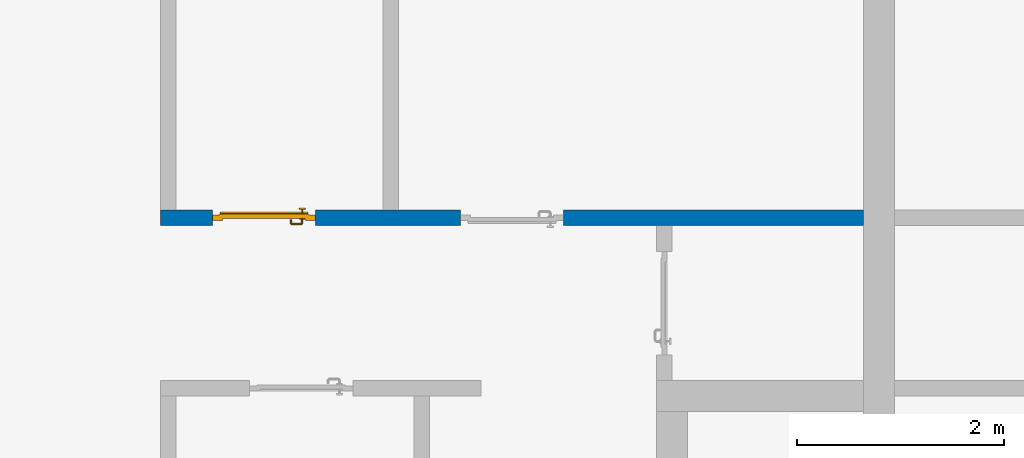
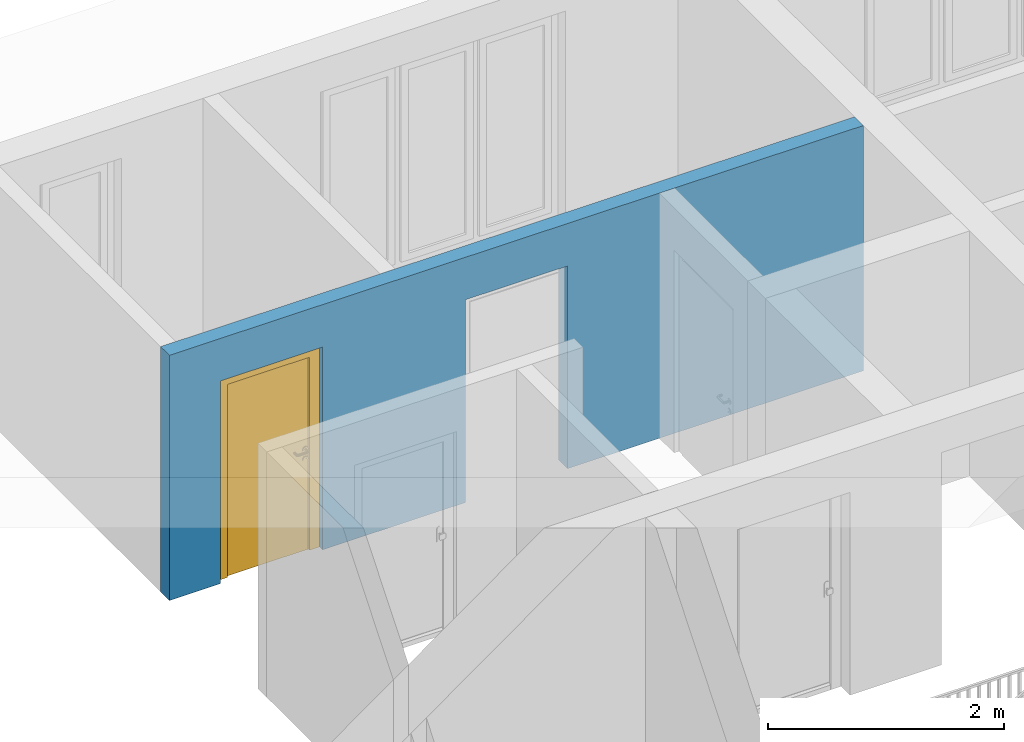
# One storey, part 24 of 54: 1 door, 1 wall, 2 openings.
"""IFC4 building model written with IfcOpenShell, lengths in metres."""

from ifc_helpers import new_model, entity, si_unit, converted_unit, derived_unit, direction, frame, origin_with_axes, place, context, subcontext, project, spatial, polygons, source, transform, mapped, material, type_object, element, fill, save


model = new_model("IFC4")

# Units and contexts
model_context = context("Model", 3, precision=1e-05, world=origin_with_axes(), true_north=direction((0.0, 1.0)))
body_context = subcontext(model_context, "Body", "Model", "MODEL_VIEW")
ifc_project = project(units=[si_unit("LENGTHUNIT", "METRE"), si_unit("AREAUNIT", "SQUARE_METRE"), si_unit("VOLUMEUNIT", "CUBIC_METRE"), converted_unit("PLANEANGLEUNIT", "DEGREE", entity("IfcPlaneAngleMeasure", 0.0174532925199), si_unit("PLANEANGLEUNIT", "RADIAN"), dimensions=[0, 0, 0, 0, 0, 0, 0]), converted_unit("TIMEUNIT", "Year", entity("IfcTimeMeasure", 31556926.0), si_unit("TIMEUNIT", "SECOND"), dimensions=[0, 0, 1, 0, 0, 0, 0]), si_unit("MASSUNIT", "GRAM", prefix="KILO"), si_unit("THERMODYNAMICTEMPERATUREUNIT", "DEGREE_CELSIUS"), si_unit("LUMINOUSINTENSITYUNIT", "LUMEN"), si_unit("ENERGYUNIT", "JOULE", prefix="MEGA"), derived_unit("THERMALCONDUCTANCEUNIT", [(si_unit("POWERUNIT", "WATT"), 1), (si_unit("LENGTHUNIT", "METRE"), -1), (si_unit("THERMODYNAMICTEMPERATUREUNIT", "KELVIN"), -1)]), derived_unit("SPECIFICHEATCAPACITYUNIT", [(si_unit("ENERGYUNIT", "JOULE"), 1), (si_unit("MASSUNIT", "GRAM", prefix="KILO"), -1), (si_unit("THERMODYNAMICTEMPERATUREUNIT", "KELVIN"), -1)]), derived_unit("MASSDENSITYUNIT", [(si_unit("MASSUNIT", "GRAM", prefix="KILO"), 1), (si_unit("VOLUMEUNIT", "CUBIC_METRE"), -1)])], contexts=[model_context])

# Site, building, storey
site_placement = place(None, origin_with_axes())
site = spatial("IfcSite", under=ifc_project, at=site_placement, CompositionType="ELEMENT")
building_placement = place(site_placement, origin_with_axes())
building = spatial("IfcBuilding", under=site, at=building_placement, CompositionType="ELEMENT")
storey_placement = place(building_placement, frame((0.0, 0.0, 6.29), z_axis=(0.0, 0.0, 1.0), x_axis=(1.0, 0.0, 0.0)))
storey = spatial("IfcBuildingStorey", under=building, at=storey_placement, Name="2. Geschoss", CompositionType="ELEMENT", Elevation=6.29)

# Wall, openings, door
ifc_material = material()
wall_type = type_object("IfcWallType", Name="150", PredefinedType="NOTDEFINED")
wall_placement = place(storey_placement, frame((-7.5421993804, 5.47118776896, 0.0), z_axis=(0.0, 0.0, 1.0), x_axis=(1.0, 0.0, 0.0)))
wall = element("IfcWall", 1, at=wall_placement, inside=storey, type_object=wall_type, material=ifc_material, Name="Wand-002", PredefinedType="NOTDEFINED", context=body_context, shape_type="Tessellation", body=[
    polygons([(2.9, 0.15, 2.1), (2.9, 0.15, 0.0), (1.5, 0.15, 0.0), (1.5, 0.15, 2.1), (0.5, 0.15, 2.1), (0.5, 0.15, 0.0), (0.0, 0.15, 0.0), (0.0, 0.15, 2.54), (6.8, 0.15, 2.54), (6.8, 0.15, 0.0), (3.9, 0.15, 0.0), (3.9, 0.15, 2.1), (2.9, 0.05, 2.1), (2.9, 0.05, 0.0), (2.9, 0.0, 0.0), (1.5, 0.0, 0.0), (1.5, 0.1, 0.0), (1.5, 0.1, 2.1), (0.5, 0.1, 2.1), (0.5, 0.1, 0.0), (0.5, 0.0, 0.0), (0.0, 0.0, 0.0), (0.0, 0.0, 2.54), (6.8, 0.0, 2.54), (6.8, 0.0, 0.0), (3.9, 0.05, 0.0), (3.9, 0.0, 0.0), (3.9, 0.05, 2.1), (2.9, 0.0, 2.1), (3.9, 0.0, 2.1), (0.5, 0.0, 2.1), (1.5, 0.0, 2.1)], [[[1, 2, 3, 4, 5, 6, 7, 8, 9, 10, 11, 12]], [[2, 1, 13, 14]], [[2, 14, 15, 16, 17, 3]], [[4, 3, 17, 18]], [[5, 4, 18, 19]], [[6, 5, 19, 20]], [[6, 20, 21, 22, 7]], [[22, 23, 8, 7]], [[23, 24, 9, 8]], [[10, 9, 24, 25]], [[26, 11, 10, 25, 27]], [[12, 11, 26, 28]], [[1, 12, 28, 13]], [[14, 13, 29, 15]], [[16, 15, 29, 30, 27, 25, 24, 23, 22, 21, 31, 32]], [[16, 32, 18, 17]], [[32, 31, 19, 18]], [[31, 21, 20, 19]], [[28, 26, 27, 30]], [[13, 28, 30, 29]]], closed=True),
])
opening_1_placement = place(wall_placement, frame((1.0, 0.0, 0.0), z_axis=(0.0, 0.0, 1.0), x_axis=(1.0, 0.0, 0.0)))
opening_1 = element("IfcOpeningElement", 2, at=opening_1_placement, cuts=wall, context=body_context, identifier="Reference", shape_type="Tessellation", body=[
    polygons([(-0.5, 0.1, 0.0), (-0.5, 0.1, 2.1), (-0.5, 0.151, 2.1), (-0.5, 0.151, 0.0), (-0.5, -0.001, 0.0), (-0.5, -0.001, 2.1), (0.5, 0.1, 2.1), (0.5, 0.151, 2.1), (0.5, -0.001, 2.1), (0.5, 0.151, 0.0), (0.5, 0.1, 0.0), (0.5, -0.001, 0.0)], [[[1, 2, 3, 4]], [[2, 1, 5, 6]], [[7, 8, 3, 2, 6, 9]], [[8, 10, 4, 3]], [[1, 4, 10, 11, 12, 5]], [[6, 5, 12, 9]], [[7, 11, 10, 8]], [[11, 7, 9, 12]]], closed=True),
])
opening_2_placement = place(wall_placement, frame((3.4, 0.0, 0.0), z_axis=(0.0, 0.0, 1.0), x_axis=(1.0, 0.0, 0.0)))
element("IfcOpeningElement", 3, at=opening_2_placement, cuts=wall, context=body_context, identifier="Reference", shape_type="Tessellation", body=[
    polygons([(0.5, 0.05, 0.0), (0.5, 0.05, 2.1), (0.5, -0.001, 2.1), (0.5, -0.001, 0.0), (0.5, 0.151, 0.0), (0.5, 0.151, 2.1), (-0.5, 0.05, 2.1), (-0.5, -0.001, 2.1), (-0.5, 0.151, 2.1), (-0.5, -0.001, 0.0), (-0.5, 0.05, 0.0), (-0.5, 0.151, 0.0)], [[[1, 2, 3, 4]], [[2, 1, 5, 6]], [[7, 8, 3, 2, 6, 9]], [[8, 10, 4, 3]], [[1, 4, 10, 11, 12, 5]], [[6, 5, 12, 9]], [[7, 11, 10, 8]], [[11, 7, 9, 12]]], closed=True),
])
door_type = type_object("IfcDoorType", Name="Eingang 01 1-Fl 26", OperationType="SINGLE_SWING_LEFT", PredefinedType="DOOR")
shared_shape = source(origin_with_axes(), body_context, "Body", "Tessellation", [
    polygons([(-0.5, -0.05, 0.0), (-0.5, -0.05, 2.1), (-0.5, -0.03, 2.1), (-0.5, -0.03, 0.0), (-0.4, -0.05, 0.0), (-0.4, -0.05, 2.0), (-0.1301, -0.05, 2.0), (-0.0001, -0.05, 2.0), (0.4, -0.05, 2.0), (0.4, -0.05, 0.0), (0.5, -0.05, 0.0), (0.5, -0.05, 2.1), (0.5, -0.03, 2.1), (0.5, -0.03, 0.0), (0.4, -0.03, 0.0), (0.4, -0.03, 2.0), (-0.0001, -0.03, 2.0), (-0.1301, -0.03, 2.0), (-0.4, -0.03, 2.0), (-0.4, -0.03, 0.0)], [[[1, 2, 3, 4]], [[1, 5, 6, 7, 8, 9, 10, 11, 12, 2]], [[2, 12, 13, 3]], [[4, 3, 13, 14, 15, 16, 17, 18, 19, 20]], [[5, 1, 4, 20]], [[6, 5, 20, 19]], [[7, 6, 19, 18]], [[8, 7, 18, 17]], [[9, 8, 17, 16]], [[10, 9, 16, 15]], [[11, 10, 15, 14]], [[12, 11, 14, 13]]], closed=True),
    polygons([(-0.5, -0.03, 0.0), (-0.5, -0.03, 2.1), (-0.5, 0.0, 2.1), (-0.5, 0.0, 0.0), (-0.43, -0.03, 0.0), (-0.43, -0.03, 2.03), (-0.1001, -0.03, 2.03), (-0.0301, -0.03, 2.03), (0.43, -0.03, 2.03), (0.43, -0.03, 0.0), (0.5, -0.03, 0.0), (0.5, -0.03, 2.1), (0.5, 0.0, 2.1), (0.5, 0.0, 0.0), (0.43, 0.0, 0.0), (0.43, 0.0, 2.03), (-0.0301, 0.0, 2.03), (-0.1001, 0.0, 2.03), (-0.43, 0.0, 2.03), (-0.43, 0.0, 0.0)], [[[1, 2, 3, 4]], [[1, 5, 6, 7, 8, 9, 10, 11, 12, 2]], [[2, 12, 13, 3]], [[4, 3, 13, 14, 15, 16, 17, 18, 19, 20]], [[5, 1, 4, 20]], [[6, 5, 20, 19]], [[7, 6, 19, 18]], [[8, 7, 18, 17]], [[9, 8, 17, 16]], [[10, 9, 16, 15]], [[11, 10, 15, 14]], [[12, 11, 14, 13]]], closed=True),
    polygons([(-0.43, 0.01, 0.0), (-0.43, 0.01, 2.03), (0.43, 0.01, 2.03), (0.43, 0.01, 0.0), (-0.43, -0.03, 0.0), (-0.43, -0.03, 2.03), (0.43, -0.03, 2.03), (0.43, -0.03, 0.0)], [[[1, 2, 3, 4]], [[1, 5, 6, 2]], [[2, 6, 7, 3]], [[3, 7, 8, 4]], [[4, 8, 5, 1]], [[8, 7, 6, 5]]], closed=True),
    polygons([(-0.425, 0.03, 0.0), (-0.425, 0.03, 0.05), (0.425, 0.03, 0.05), (0.425, 0.03, 0.0), (-0.425, 0.01, 0.0), (-0.425, 0.01, 0.07), (-0.425, 0.015, 0.07), (0.425, 0.015, 0.07), (0.425, 0.01, 0.07), (0.425, 0.01, 0.0)], [[[1, 2, 3, 4]], [[1, 5, 6, 7, 2]], [[2, 7, 8, 3]], [[4, 3, 8, 9, 10]], [[5, 1, 4, 10]], [[6, 5, 10, 9]], [[7, 6, 9, 8]]], closed=True),
    polygons([(0.3835, -0.04, 1.0733826859), (0.3835, -0.0399, 1.0733826859), (0.37, -0.0399, 1.077), (0.37, -0.04, 1.077), (0.393382685902, -0.04, 1.0635), (0.393382685902, -0.0399, 1.0635), (0.3835, -0.0301, 1.0733826859), (0.37, -0.0301, 1.077), (0.3565, -0.0399, 1.0733826859), (0.3565, -0.04, 1.0733826859), (0.346617314098, -0.04, 1.0635), (0.343, -0.04, 1.05), (0.346617314098, -0.04, 1.0365), (0.3565, -0.04, 1.0266173141), (0.37, -0.04, 1.023), (0.3835, -0.04, 1.0266173141), (0.393382685902, -0.04, 1.0365), (0.397, -0.04, 1.05), (0.397, -0.0399, 1.05), (0.393382685902, -0.0301, 1.0635), (0.3835, -0.03, 1.0733826859), (0.37, -0.03, 1.077), (0.3565, -0.0301, 1.0733826859), (0.346617314098, -0.0399, 1.0635), (0.343, -0.0399, 1.05), (0.346617314098, -0.0399, 1.0365), (0.3565, -0.0399, 1.0266173141), (0.37, -0.0399, 1.023), (0.3835, -0.0399, 1.0266173141), (0.393382685902, -0.0399, 1.0365), (0.397, -0.0301, 1.05), (0.393382685902, -0.03, 1.0635), (0.397, -0.03, 1.05), (0.393382685902, -0.03, 1.0365), (0.3835, -0.03, 1.0266173141), (0.37, -0.03, 1.023), (0.3565, -0.03, 1.0266173141), (0.346617314098, -0.03, 1.0365), (0.343, -0.03, 1.05), (0.346617314098, -0.03, 1.0635), (0.3565, -0.03, 1.0733826859), (0.346617314098, -0.0301, 1.0635), (0.343, -0.0301, 1.05), (0.346617314098, -0.0301, 1.0365), (0.3565, -0.0301, 1.0266173141), (0.37, -0.0301, 1.023), (0.3835, -0.0301, 1.0266173141), (0.393382685902, -0.0301, 1.0365)], [[[1, 2, 3, 4]], [[5, 6, 2, 1]], [[2, 7, 8, 3]], [[4, 3, 9, 10]], [[4, 10, 11, 12, 13, 14, 15, 16, 17, 18, 5, 1]], [[18, 19, 6, 5]], [[6, 20, 7, 2]], [[7, 21, 22, 8]], [[3, 8, 23, 9]], [[10, 9, 24, 11]], [[11, 24, 25, 12]], [[12, 25, 26, 13]], [[13, 26, 27, 14]], [[14, 27, 28, 15]], [[15, 28, 29, 16]], [[16, 29, 30, 17]], [[17, 30, 19, 18]], [[19, 31, 20, 6]], [[20, 32, 21, 7]], [[22, 21, 32, 33, 34, 35, 36, 37, 38, 39, 40, 41]], [[8, 22, 41, 23]], [[9, 23, 42, 24]], [[24, 42, 43, 25]], [[25, 43, 44, 26]], [[26, 44, 45, 27]], [[27, 45, 46, 28]], [[28, 46, 47, 29]], [[29, 47, 48, 30]], [[30, 48, 31, 19]], [[31, 33, 32, 20]], [[48, 34, 33, 31]], [[47, 35, 34, 48]], [[46, 36, 35, 47]], [[45, 37, 36, 46]], [[44, 38, 37, 45]], [[43, 39, 38, 44]], [[42, 40, 39, 43]], [[23, 41, 40, 42]]], closed=True),
    polygons([(0.362532169224, -0.04, 0.959692280177), (0.363279754556, -0.04, 0.961639806549), (0.35655, -0.04, 0.973296083362), (0.346703916638, -0.04, 0.96345), (0.365, -0.04, 0.952886751346), (0.365, -0.04, 0.9544), (0.362532169224, -0.039, 0.959692280177), (0.363279754556, -0.039, 0.961639806549), (0.364624817685, -0.039, 0.965143815798), (0.364624817685, -0.04, 0.965143815798), (0.37, -0.04, 0.967425445323), (0.37, -0.04, 0.9769), (0.346617314098, -0.04, 0.9635), (0.3565, -0.04, 0.973382685902), (0.365, -0.04, 0.95), (0.3431, -0.04, 0.95), (0.365, -0.04, 0.947113248654), (0.365, -0.04, 0.941339745962), (0.365, -0.04, 0.9375), (0.365, -0.039, 0.9375), (0.365, -0.039, 0.941339745962), (0.365, -0.039, 0.947113248654), (0.365, -0.039, 0.95), (0.365, -0.039, 0.952886751346), (0.365, -0.039, 0.9544), (0.347569942042, -0.039, 0.96295), (0.35705, -0.039, 0.972430057958), (0.37, -0.039, 0.9759), (0.37, -0.039, 0.967425445323), (0.375375182315, -0.04, 0.965143815798), (0.376720245444, -0.04, 0.961639806549), (0.38345, -0.04, 0.973296083362), (0.37, -0.04, 0.977), (0.343, -0.04, 0.95), (0.346617314098, -0.0399, 0.9635), (0.3565, -0.0399, 0.973382685902), (0.346703916638, -0.04, 0.93655), (0.35655, -0.04, 0.926703916638), (0.37, -0.04, 0.9231), (0.37, -0.04, 0.9325), (0.366464466094, -0.04, 0.933964466094), (0.366464466094, -0.039, 0.933964466094), (0.37, -0.039, 0.9241), (0.35705, -0.039, 0.927569942042), (0.37, -0.039, 0.9325), (0.347569942042, -0.039, 0.93705), (0.3441, -0.039, 0.95), (0.347483339502, -0.039, 0.963), (0.357, -0.039, 0.972516660498), (0.37, -0.039, 0.976), (0.375375182315, -0.039, 0.965143815798), (0.38295, -0.039, 0.972430057958), (0.376720245444, -0.039, 0.961639806549), (0.377467830776, -0.039, 0.959692280177), (0.377467830776, -0.04, 0.959692280177), (0.375, -0.04, 0.9544), (0.375, -0.04, 0.952886751346), (0.393296083362, -0.04, 0.96345), (0.3835, -0.04, 0.973382685902), (0.37, -0.0399, 0.977), (0.346617314098, -0.04, 0.9365), (0.343, -0.0399, 0.95), (0.346617314098, -0.0301, 0.9635), (0.3565, -0.0301, 0.973382685902), (0.3565, -0.04, 0.926617314098), (0.37, -0.04, 0.923), (0.38345, -0.04, 0.926703916638), (0.375, -0.04, 0.941339745962), (0.375, -0.04, 0.9375), (0.373535533906, -0.04, 0.933964466094), (0.37, -0.039, 0.924), (0.357, -0.039, 0.927483339502), (0.38295, -0.039, 0.927569942042), (0.373535533906, -0.039, 0.933964466094), (0.375, -0.039, 0.9375), (0.375, -0.039, 0.941339745962), (0.347483339502, -0.039, 0.937), (0.344, -0.039, 0.95), (0.347483339502, -0.0389, 0.963), (0.357, -0.0389, 0.972516660498), (0.37, -0.0389, 0.976), (0.383, -0.039, 0.972516660498), (0.392430057958, -0.039, 0.96295), (0.375, -0.039, 0.952886751346), (0.375, -0.039, 0.9544), (0.375, -0.039, 0.95), (0.375, -0.039, 0.947113248654), (0.375, -0.04, 0.947113248654), (0.375, -0.04, 0.95), (0.3969, -0.04, 0.95), (0.393382685902, -0.04, 0.9635), (0.3835, -0.0399, 0.973382685902), (0.37, -0.0301, 0.977), (0.346617314098, -0.0399, 0.9365), (0.343, -0.0301, 0.95), (0.346617314098, -0.03, 0.9635), (0.3565, -0.03, 0.973382685902), (0.3565, -0.0399, 0.926617314098), (0.3835, -0.04, 0.926617314098), (0.37, -0.0399, 0.923), (0.393296083362, -0.04, 0.93655), (0.383, -0.039, 0.927483339502), (0.37, -0.0389, 0.924), (0.357, -0.0389, 0.927483339502), (0.392430057958, -0.039, 0.93705), (0.347483339502, -0.0389, 0.937), (0.344, -0.0389, 0.95), (0.347483339502, -0.0301, 0.963), (0.357, -0.0301, 0.972516660498), (0.37, -0.0301, 0.976), (0.383, -0.0389, 0.972516660498), (0.392516660498, -0.039, 0.963), (0.3959, -0.039, 0.95), (0.397, -0.04, 0.95), (0.393382685902, -0.0399, 0.9635), (0.3835, -0.0301, 0.973382685902), (0.37, -0.03, 0.977), (0.346617314098, -0.0301, 0.9365), (0.343, -0.03, 0.95), (0.346703916638, -0.03, 0.96345), (0.35655, -0.03, 0.973296083362), (0.3565, -0.0301, 0.926617314098), (0.393382685902, -0.04, 0.9365), (0.3835, -0.0399, 0.926617314098), (0.37, -0.0301, 0.923), (0.392516660498, -0.039, 0.937), (0.383, -0.0389, 0.927483339502), (0.37, -0.0301, 0.924), (0.357, -0.0301, 0.927483339502), (0.347483339502, -0.0301, 0.937), (0.344, -0.0301, 0.95), (0.347483339502, -0.03, 0.963), (0.357, -0.03, 0.972516660498), (0.37, -0.03, 0.976), (0.383, -0.0301, 0.972516660498), (0.392516660498, -0.0389, 0.963), (0.396, -0.039, 0.95), (0.397, -0.0399, 0.95), (0.393382685902, -0.0301, 0.9635), (0.3835, -0.03, 0.973382685902), (0.37, -0.03, 0.9769), (0.346617314098, -0.03, 0.9365), (0.3431, -0.03, 0.95), (0.347396736961, -0.03, 0.96305), (0.35695, -0.03, 0.972603263039), (0.3565, -0.03, 0.926617314098), (0.393382685902, -0.0399, 0.9365), (0.3835, -0.0301, 0.926617314098), (0.37, -0.03, 0.923), (0.392516660498, -0.0389, 0.937), (0.383, -0.0301, 0.927483339502), (0.37, -0.03, 0.924), (0.357, -0.03, 0.927483339502), (0.347483339502, -0.03, 0.937), (0.344, -0.03, 0.95), (0.37, -0.03, 0.9761), (0.383, -0.03, 0.972516660498), (0.392516660498, -0.0301, 0.963), (0.396, -0.0389, 0.95), (0.397, -0.0301, 0.95), (0.393382685902, -0.03, 0.9635), (0.38345, -0.03, 0.973296083362), (0.346703916638, -0.03, 0.93655), (0.3439, -0.03, 0.95), (0.35655, -0.03, 0.926703916638), (0.393382685902, -0.0301, 0.9365), (0.3835, -0.03, 0.926617314098), (0.37, -0.03, 0.9231), (0.392516660498, -0.0301, 0.937), (0.383, -0.03, 0.927483339502), (0.37, -0.03, 0.9239), (0.35695, -0.03, 0.927396736961), (0.347396736961, -0.03, 0.93695), (0.38305, -0.03, 0.972603263039), (0.392516660498, -0.03, 0.963), (0.396, -0.0301, 0.95), (0.397, -0.03, 0.95), (0.393296083362, -0.03, 0.96345), (0.393382685902, -0.03, 0.9365), (0.38345, -0.03, 0.926703916638), (0.392516660498, -0.03, 0.937), (0.38305, -0.03, 0.927396736961), (0.392603263039, -0.03, 0.96305), (0.396, -0.03, 0.95), (0.3969, -0.03, 0.95), (0.393296083362, -0.03, 0.93655), (0.392603263039, -0.03, 0.93695), (0.3961, -0.03, 0.95)], [[[1, 2, 3, 4, 5, 6]], [[1, 7, 8, 9, 10, 2]], [[10, 11, 12, 3, 2]], [[13, 4, 3, 14]], [[15, 5, 4, 16]], [[6, 5, 15, 17, 18, 19, 20, 21, 22, 23, 24, 25]], [[6, 25, 7, 1]], [[7, 25, 24, 26, 27, 8]], [[9, 8, 27, 28, 29]], [[10, 9, 29, 11]], [[30, 31, 32, 12, 11]], [[14, 3, 12, 33]], [[34, 16, 4, 13]], [[35, 13, 14, 36]], [[17, 15, 16, 37]], [[18, 17, 37, 38]], [[38, 39, 40, 41, 19, 18]], [[19, 41, 42, 20]], [[43, 44, 21, 20, 42, 45]], [[22, 21, 44, 46]], [[23, 22, 46, 47]], [[24, 23, 47, 26]], [[26, 48, 49, 27]], [[27, 49, 50, 28]], [[51, 29, 28, 52, 53]], [[11, 29, 51, 30]], [[30, 51, 53, 54, 55, 31]], [[55, 56, 57, 58, 32, 31]], [[33, 12, 32, 59]], [[36, 14, 33, 60]], [[61, 37, 16, 34]], [[62, 34, 13, 35]], [[63, 35, 36, 64]], [[65, 38, 37, 61]], [[66, 39, 38, 65]], [[39, 67, 68, 69, 70, 40]], [[41, 40, 45, 42]], [[43, 71, 72, 44]], [[73, 43, 45, 74, 75, 76]], [[44, 72, 77, 46]], [[46, 77, 78, 47]], [[47, 78, 48, 26]], [[48, 79, 80, 49]], [[49, 80, 81, 50]], [[28, 50, 82, 52]], [[54, 53, 52, 83, 84, 85]], [[55, 54, 85, 56]], [[85, 84, 86, 87, 76, 75, 69, 68, 88, 89, 57, 56]], [[57, 89, 90, 58]], [[59, 32, 58, 91]], [[60, 33, 59, 92]], [[64, 36, 60, 93]], [[94, 61, 34, 62]], [[95, 62, 35, 63]], [[96, 63, 64, 97]], [[98, 65, 61, 94]], [[99, 67, 39, 66]], [[100, 66, 65, 98]], [[88, 68, 67, 101]], [[70, 69, 75, 74]], [[40, 70, 74, 45]], [[73, 102, 71, 43]], [[71, 103, 104, 72]], [[76, 87, 105, 73]], [[72, 104, 106, 77]], [[77, 106, 107, 78]], [[78, 107, 79, 48]], [[79, 108, 109, 80]], [[80, 109, 110, 81]], [[50, 81, 111, 82]], [[52, 82, 112, 83]], [[86, 84, 83, 113]], [[87, 86, 113, 105]], [[89, 88, 101, 90]], [[91, 58, 90, 114]], [[92, 59, 91, 115]], [[93, 60, 92, 116]], [[97, 64, 93, 117]], [[118, 94, 62, 95]], [[119, 95, 63, 96]], [[120, 96, 97, 121]], [[122, 98, 94, 118]], [[123, 101, 67, 99]], [[124, 99, 66, 100]], [[125, 100, 98, 122]], [[105, 126, 102, 73]], [[102, 127, 103, 71]], [[103, 128, 129, 104]], [[104, 129, 130, 106]], [[106, 130, 131, 107]], [[107, 131, 108, 79]], [[108, 132, 133, 109]], [[109, 133, 134, 110]], [[81, 110, 135, 111]], [[82, 111, 136, 112]], [[83, 112, 137, 113]], [[113, 137, 126, 105]], [[114, 90, 101, 123]], [[115, 91, 114, 138]], [[116, 92, 115, 139]], [[117, 93, 116, 140]], [[121, 97, 117, 141]], [[142, 118, 95, 119]], [[143, 119, 96, 120]], [[144, 120, 121, 145]], [[146, 122, 118, 142]], [[147, 123, 99, 124]], [[148, 124, 100, 125]], [[149, 125, 122, 146]], [[126, 150, 127, 102]], [[127, 151, 128, 103]], [[128, 152, 153, 129]], [[129, 153, 154, 130]], [[130, 154, 155, 131]], [[131, 155, 132, 108]], [[132, 144, 145, 133]], [[133, 145, 156, 134]], [[110, 134, 157, 135]], [[111, 135, 158, 136]], [[112, 136, 159, 137]], [[137, 159, 150, 126]], [[138, 114, 123, 147]], [[139, 115, 138, 160]], [[140, 116, 139, 161]], [[141, 117, 140, 162]], [[145, 121, 141, 156]], [[163, 142, 119, 143]], [[164, 143, 120, 144]], [[165, 146, 142, 163]], [[166, 147, 124, 148]], [[167, 148, 125, 149]], [[168, 149, 146, 165]], [[150, 169, 151, 127]], [[151, 170, 152, 128]], [[152, 171, 172, 153]], [[153, 172, 173, 154]], [[154, 173, 164, 155]], [[155, 164, 144, 132]], [[134, 156, 174, 157]], [[135, 157, 175, 158]], [[136, 158, 176, 159]], [[159, 176, 169, 150]], [[160, 138, 147, 166]], [[161, 139, 160, 177]], [[162, 140, 161, 178]], [[156, 141, 162, 174]], [[173, 163, 143, 164]], [[172, 165, 163, 173]], [[179, 166, 148, 167]], [[180, 167, 149, 168]], [[171, 168, 165, 172]], [[169, 181, 170, 151]], [[170, 182, 171, 152]], [[157, 174, 183, 175]], [[158, 175, 184, 176]], [[176, 184, 181, 169]], [[177, 160, 166, 179]], [[178, 161, 177, 185]], [[174, 162, 178, 183]], [[186, 179, 167, 180]], [[182, 180, 168, 171]], [[181, 187, 182, 170]], [[175, 183, 188, 184]], [[184, 188, 187, 181]], [[185, 177, 179, 186]], [[183, 178, 185, 188]], [[187, 186, 180, 182]], [[188, 185, 186, 187]]], closed=True),
    polygons([(0.38, -0.04, 1.05), (0.38, -0.0709849140336, 1.05), (0.377071067812, -0.070696439392, 1.04292893219), (0.377071067812, -0.04, 1.04292893219), (0.377071067812, -0.04, 1.05707106781), (0.377071067812, -0.070696439392, 1.05707106781), (0.378277987014, -0.0796420579258, 1.05), (0.375518993221, -0.0784992452783, 1.04292893219), (0.37, -0.07, 1.04), (0.37, -0.04, 1.04), (0.37, -0.04, 1.06), (0.37, -0.07, 1.06), (0.375518993221, -0.0784992452783, 1.05707106781), (0.372816199938, -0.0878161999379, 1.05), (0.370704557509, -0.0857045575088, 1.04292893219), (0.368858192988, -0.0757402514855, 1.04), (0.362928932188, -0.069303560608, 1.04292893219), (0.362928932188, -0.04, 1.04292893219), (0.362928932188, -0.04, 1.05707106781), (0.362928932188, -0.069303560608, 1.05707106781), (0.368858192988, -0.0757402514855, 1.06), (0.370704557509, -0.0857045575088, 1.05707106781), (0.364642057926, -0.0932779870137, 1.05), (0.363499245278, -0.0905189932208, 1.04292893219), (0.365606601718, -0.0806066017178, 1.04), (0.362197392755, -0.0729812576926, 1.04292893219), (0.36, -0.0690150859664, 1.05), (0.36, -0.04, 1.05), (0.362197392755, -0.0729812576926, 1.05707106781), (0.365606601718, -0.0806066017178, 1.06), (0.363499245278, -0.0905189932208, 1.05707106781), (0.355984914034, -0.095, 1.05), (0.355696439392, -0.0920710678119, 1.04292893219), (0.360740251485, -0.0838581929877, 1.04), (0.360508645927, -0.0755086459268, 1.04292893219), (0.359438398962, -0.0718384450452, 1.05), (0.360508645927, -0.0755086459268, 1.05707106781), (0.360740251485, -0.0838581929877, 1.06), (0.355696439392, -0.0920710678119, 1.05707106781), (0.274015085966, -0.095, 1.05), (0.274303560608, -0.0920710678119, 1.04292893219), (0.355, -0.085, 1.04), (0.357981257693, -0.0771973927545, 1.04292893219), (0.358397003498, -0.0733970034977, 1.05), (0.357981257693, -0.0771973927545, 1.05707106781), (0.355, -0.085, 1.06), (0.274303560608, -0.0920710678119, 1.05707106781), (0.265357942074, -0.0932779870137, 1.05), (0.266500754722, -0.0905189932208, 1.04292893219), (0.275, -0.085, 1.04), (0.354303560608, -0.0779289321881, 1.04292893219), (0.356838445045, -0.0744383989617, 1.05), (0.354303560608, -0.0779289321881, 1.05707106781), (0.275, -0.085, 1.06), (0.266500754722, -0.0905189932208, 1.05707106781), (0.257183800062, -0.0878161999379, 1.05), (0.259295442491, -0.0857045575088, 1.04292893219), (0.269259748515, -0.0838581929877, 1.04), (0.275696439392, -0.0779289321881, 1.04292893219), (0.354015085966, -0.075, 1.05), (0.275696439392, -0.0779289321881, 1.05707106781), (0.269259748515, -0.0838581929877, 1.06), (0.259295442491, -0.0857045575088, 1.05707106781), (0.251722012986, -0.0796420579258, 1.05), (0.254481006779, -0.0784992452783, 1.04292893219), (0.264393398282, -0.0806066017178, 1.04), (0.272018742307, -0.0771973927545, 1.04292893219), (0.275984914034, -0.075, 1.05), (0.272018742307, -0.0771973927545, 1.05707106781), (0.264393398282, -0.0806066017178, 1.06), (0.254481006779, -0.0784992452783, 1.05707106781), (0.25, -0.0709849140336, 1.05), (0.252928932188, -0.070696439392, 1.04292893219), (0.261141807012, -0.0757402514855, 1.04), (0.269491354073, -0.0755086459268, 1.04292893219), (0.273161554955, -0.0744383989617, 1.05), (0.269491354073, -0.0755086459268, 1.05707106781), (0.261141807012, -0.0757402514855, 1.06), (0.252928932188, -0.070696439392, 1.05707106781), (0.25, -0.04, 1.05), (0.252928932188, -0.04, 1.04292893219), (0.26, -0.07, 1.04), (0.267802607245, -0.0729812576926, 1.04292893219), (0.271602996502, -0.0733970034977, 1.05), (0.267802607245, -0.0729812576926, 1.05707106781), (0.26, -0.07, 1.06), (0.252928932188, -0.04, 1.05707106781), (0.26, -0.04, 1.06), (0.267071067812, -0.04, 1.05707106781), (0.27, -0.04, 1.05), (0.267071067812, -0.04, 1.04292893219), (0.26, -0.04, 1.04), (0.267071067812, -0.069303560608, 1.04292893219), (0.270561601038, -0.0718384450452, 1.05), (0.267071067812, -0.069303560608, 1.05707106781), (0.27, -0.0690150859664, 1.05)], [[[1, 2, 3, 4]], [[5, 6, 2, 1]], [[2, 7, 8, 3]], [[4, 3, 9, 10]], [[11, 12, 6, 5]], [[6, 13, 7, 2]], [[7, 14, 15, 8]], [[3, 8, 16, 9]], [[10, 9, 17, 18]], [[19, 20, 12, 11]], [[12, 21, 13, 6]], [[13, 22, 14, 7]], [[14, 23, 24, 15]], [[8, 15, 25, 16]], [[9, 16, 26, 17]], [[18, 17, 27, 28]], [[28, 27, 20, 19]], [[20, 29, 21, 12]], [[21, 30, 22, 13]], [[22, 31, 23, 14]], [[23, 32, 33, 24]], [[15, 24, 34, 25]], [[16, 25, 35, 26]], [[17, 26, 36, 27]], [[27, 36, 29, 20]], [[29, 37, 30, 21]], [[30, 38, 31, 22]], [[31, 39, 32, 23]], [[32, 40, 41, 33]], [[24, 33, 42, 34]], [[25, 34, 43, 35]], [[26, 35, 44, 36]], [[36, 44, 37, 29]], [[37, 45, 38, 30]], [[38, 46, 39, 31]], [[39, 47, 40, 32]], [[40, 48, 49, 41]], [[33, 41, 50, 42]], [[34, 42, 51, 43]], [[35, 43, 52, 44]], [[44, 52, 45, 37]], [[45, 53, 46, 38]], [[46, 54, 47, 39]], [[47, 55, 48, 40]], [[48, 56, 57, 49]], [[41, 49, 58, 50]], [[42, 50, 59, 51]], [[43, 51, 60, 52]], [[52, 60, 53, 45]], [[53, 61, 54, 46]], [[54, 62, 55, 47]], [[55, 63, 56, 48]], [[56, 64, 65, 57]], [[49, 57, 66, 58]], [[50, 58, 67, 59]], [[51, 59, 68, 60]], [[60, 68, 61, 53]], [[61, 69, 62, 54]], [[62, 70, 63, 55]], [[63, 71, 64, 56]], [[64, 72, 73, 65]], [[57, 65, 74, 66]], [[58, 66, 75, 67]], [[59, 67, 76, 68]], [[68, 76, 69, 61]], [[69, 77, 70, 62]], [[70, 78, 71, 63]], [[71, 79, 72, 64]], [[72, 80, 81, 73]], [[65, 73, 82, 74]], [[66, 74, 83, 75]], [[67, 75, 84, 76]], [[76, 84, 77, 69]], [[77, 85, 78, 70]], [[78, 86, 79, 71]], [[79, 87, 80, 72]], [[80, 87, 88, 89, 90, 91, 92, 81]], [[73, 81, 92, 82]], [[74, 82, 93, 83]], [[75, 83, 94, 84]], [[84, 94, 85, 77]], [[85, 95, 86, 78]], [[86, 88, 87, 79]], [[95, 89, 88, 86]], [[96, 90, 89, 95]], [[93, 91, 90, 96]], [[82, 92, 91, 93]], [[83, 93, 96, 94]], [[94, 96, 95, 85]]], closed=False),
    polygons([(0.364696699141, 0.015, 1.04469669914), (0.37, 0.015, 1.0425), (0.375303300859, 0.015, 1.04469669914), (0.3775, 0.015, 1.05), (0.375303300859, 0.015, 1.05530330086), (0.37, 0.015, 1.0575), (0.364696699141, 0.015, 1.05530330086), (0.3625, 0.015, 1.05), (0.364696699141, 0.055, 1.04469669914), (0.37, 0.055, 1.0425), (0.375303300859, 0.055, 1.04469669914), (0.3775, 0.055, 1.05), (0.375303300859, 0.055, 1.05530330086), (0.37, 0.055, 1.0575), (0.364696699141, 0.055, 1.05530330086), (0.3625, 0.055, 1.05)], [[[1, 2, 3, 4, 5, 6, 7, 8]], [[2, 1, 9, 10]], [[3, 2, 10, 11]], [[4, 3, 11, 12]], [[5, 4, 12, 13]], [[6, 5, 13, 14]], [[7, 6, 14, 15]], [[8, 7, 15, 16]], [[1, 8, 16, 9]], [[9, 16, 15, 14, 13, 12, 11, 10]]], closed=True),
    polygons([(0.395, 0.01, 0.975), (0.393096988313, 0.01, 0.965432914191), (0.393096988313, 0.015, 0.965432914191), (0.395, 0.015, 0.975), (0.395, 0.01, 1.1), (0.393096988313, 0.01, 1.10956708581), (0.38767766953, 0.01, 1.11767766953), (0.379567085809, 0.01, 1.12309698831), (0.37, 0.01, 1.125), (0.360432914191, 0.01, 1.12309698831), (0.35232233047, 0.01, 1.11767766953), (0.346903011687, 0.01, 1.10956708581), (0.345, 0.01, 1.1), (0.345, 0.01, 0.975), (0.346903011687, 0.01, 0.965432914191), (0.35232233047, 0.01, 0.95732233047), (0.360432914191, 0.01, 0.951903011687), (0.37, 0.01, 0.95), (0.379567085809, 0.01, 0.951903011687), (0.38767766953, 0.01, 0.95732233047), (0.38767766953, 0.015, 0.95732233047), (0.379567085809, 0.015, 0.951903011687), (0.37, 0.015, 0.95), (0.360432914191, 0.015, 0.951903011687), (0.35232233047, 0.015, 0.95732233047), (0.346903011687, 0.015, 0.965432914191), (0.345, 0.015, 0.975), (0.345, 0.015, 1.1), (0.346903011687, 0.015, 1.10956708581), (0.35232233047, 0.015, 1.11767766953), (0.360432914191, 0.015, 1.12309698831), (0.37, 0.015, 1.125), (0.379567085809, 0.015, 1.12309698831), (0.38767766953, 0.015, 1.11767766953), (0.393096988313, 0.015, 1.10956708581), (0.395, 0.015, 1.1)], [[[1, 2, 3, 4]], [[1, 5, 6, 7, 8, 9, 10, 11, 12, 13, 14, 15, 16, 17, 18, 19, 20, 2]], [[2, 20, 21, 3]], [[4, 3, 21, 22, 23, 24, 25, 26, 27, 28, 29, 30, 31, 32, 33, 34, 35, 36]], [[5, 1, 4, 36]], [[6, 5, 36, 35]], [[7, 6, 35, 34]], [[8, 7, 34, 33]], [[9, 8, 33, 32]], [[10, 9, 32, 31]], [[11, 10, 31, 30]], [[12, 11, 30, 29]], [[13, 12, 29, 28]], [[14, 13, 28, 27]], [[15, 14, 27, 26]], [[16, 15, 26, 25]], [[17, 16, 25, 24]], [[18, 17, 24, 23]], [[19, 18, 23, 22]], [[20, 19, 22, 21]]], closed=True),
    polygons([(0.39, 0.055, 1.08), (0.395, 0.055, 1.07866025404), (0.395, 0.07, 1.07866025404), (0.39, 0.07, 1.08), (0.35, 0.055, 1.08), (0.345, 0.055, 1.07866025404), (0.341339745962, 0.055, 1.075), (0.34, 0.055, 1.07), (0.34, 0.055, 1.03), (0.341339745962, 0.055, 1.025), (0.345, 0.055, 1.02133974596), (0.35, 0.055, 1.02), (0.39, 0.055, 1.02), (0.395, 0.055, 1.02133974596), (0.398660254038, 0.055, 1.025), (0.4, 0.055, 1.03), (0.4, 0.055, 1.07), (0.398660254038, 0.055, 1.075), (0.398660254038, 0.07, 1.075), (0.4, 0.07, 1.07), (0.4, 0.07, 1.03), (0.398660254038, 0.07, 1.025), (0.395, 0.07, 1.02133974596), (0.39, 0.07, 1.02), (0.35, 0.07, 1.02), (0.345, 0.07, 1.02133974596), (0.341339745962, 0.07, 1.025), (0.34, 0.07, 1.03), (0.34, 0.07, 1.07), (0.341339745962, 0.07, 1.075), (0.345, 0.07, 1.07866025404), (0.35, 0.07, 1.08)], [[[1, 2, 3, 4]], [[1, 5, 6, 7, 8, 9, 10, 11, 12, 13, 14, 15, 16, 17, 18, 2]], [[2, 18, 19, 3]], [[4, 3, 19, 20, 21, 22, 23, 24, 25, 26, 27, 28, 29, 30, 31, 32]], [[5, 1, 4, 32]], [[6, 5, 32, 31]], [[7, 6, 31, 30]], [[8, 7, 30, 29]], [[9, 8, 29, 28]], [[10, 9, 28, 27]], [[11, 10, 27, 26]], [[12, 11, 26, 25]], [[13, 12, 25, 24]], [[14, 13, 24, 23]], [[15, 14, 23, 22]], [[16, 15, 22, 21]], [[17, 16, 21, 20]], [[18, 17, 20, 19]]], closed=True),
])
door_placement = place(opening_1_placement, frame((-0.4, 0.0, 0.0), z_axis=(0.0, 0.0, 1.0), x_axis=(1.0, 0.0, 0.0)))
door = element("IfcDoor", 4, at=door_placement, inside=storey, type_object=door_type, OverallHeight=2.1, OverallWidth=1.0, PredefinedType="DOOR", context=body_context, shape_type="MappedRepresentation", body=[
    mapped(shared_shape, transform((0.4, 0.1, 0.0))),
])
fill(opening_1, door)

save(model, "model.ifc")
